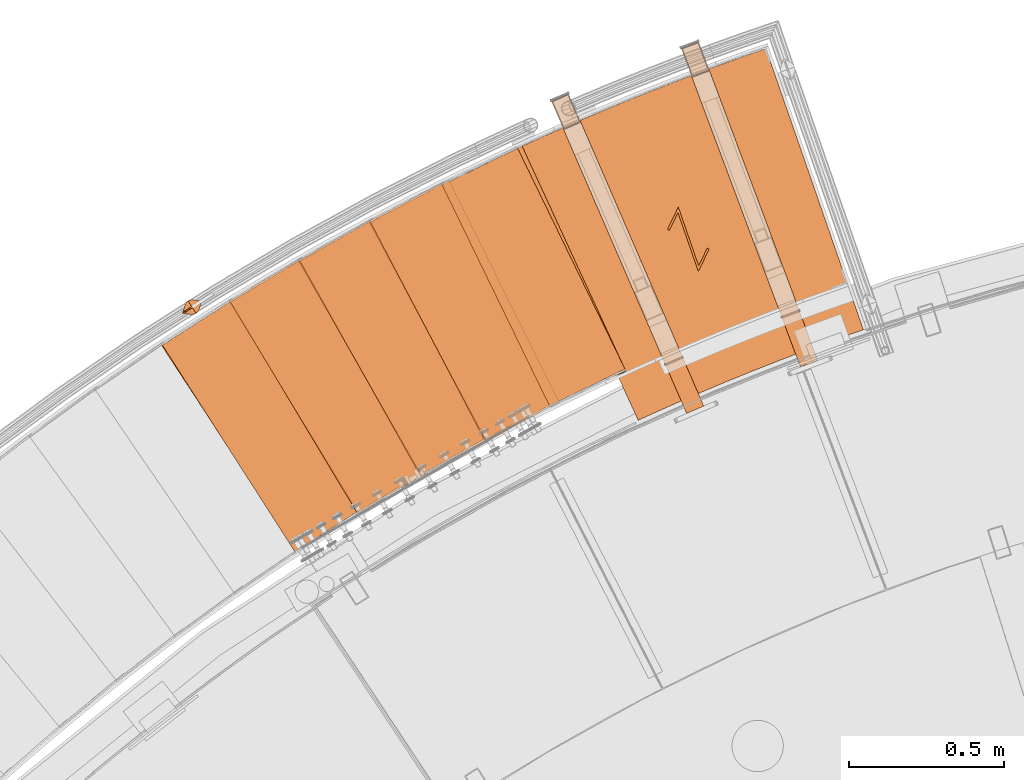
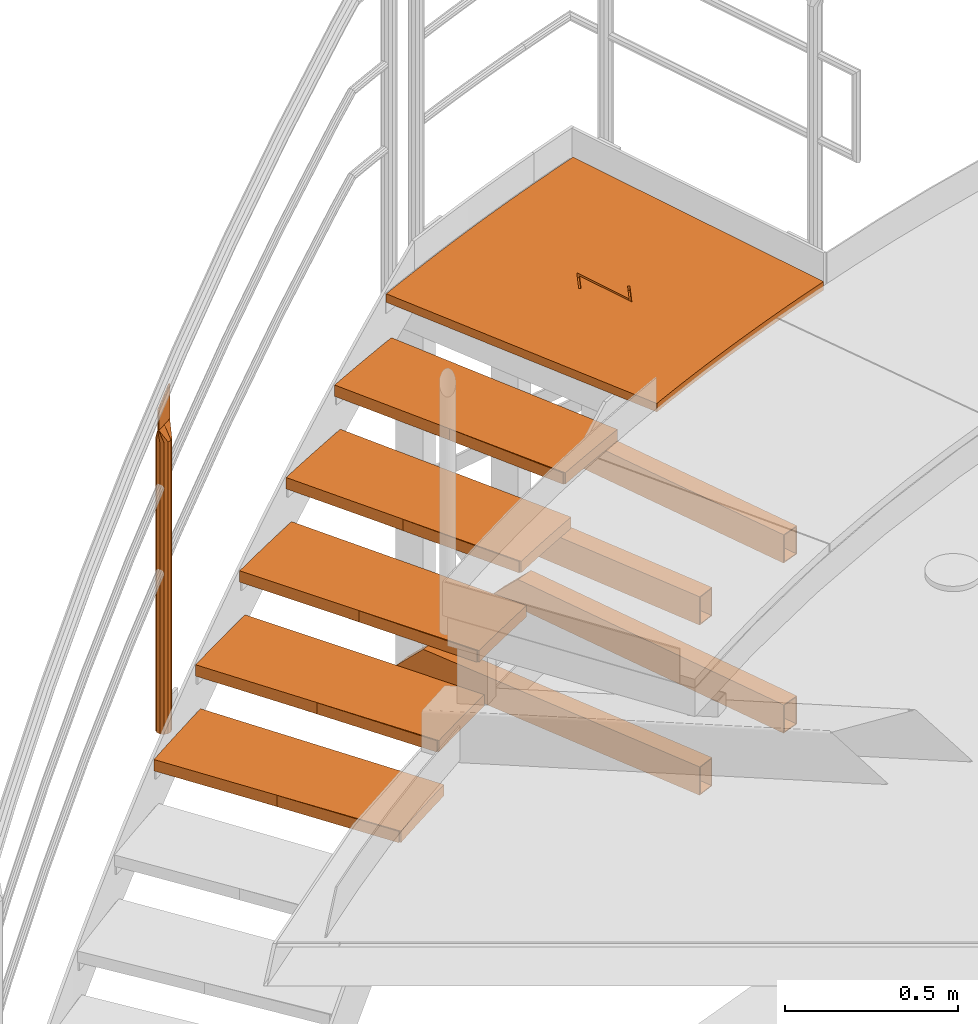
# One storey, part 37 of 126: 16 proxies.
"""IFC2X3 building model written with IfcOpenShell, lengths in millimetres."""

from ifc_helpers import new_model, si_unit, origin, origin_with_axes, place, context, project, spatial, faceted_brep, material, element, save


model = new_model("IFC2X3")

# Units and contexts
context_of_model_1 = context(None, 3, precision=0.1, world=origin())
context_of_model_2 = context(None, 3, precision=0.1, world=origin())
ifc_project = project(units=[si_unit("LENGTHUNIT", "METRE", prefix="MILLI"), si_unit("AREAUNIT", "SQUARE_METRE", prefix="CENTI"), si_unit("VOLUMEUNIT", "CUBIC_METRE", prefix="CENTI"), si_unit("MASSUNIT", "GRAM", prefix="KILO")], contexts=[context_of_model_1, context_of_model_2])

# Site, building, storey
site_placement = place(None, origin_with_axes())
site = spatial("IfcSite", under=ifc_project, at=site_placement, CompositionType="ELEMENT")
building_placement = place(site_placement, origin_with_axes())
building = spatial("IfcBuilding", under=site, at=building_placement, CompositionType="ELEMENT")
storey_placement = place(building_placement, origin_with_axes())
storey = spatial("IfcBuildingStorey", under=building, at=storey_placement, CompositionType="ELEMENT")

# Proxies
ifc_material_1 = material(Name="HOLZ")
proxy_1_placement = place(storey_placement, origin_with_axes())
element("IfcBuildingElementProxy", 1, at=proxy_1_placement, inside=storey, material=ifc_material_1, context=context_of_model_2, shape_type="Brep", body=[
    faceted_brep([(3425.4869, 15539.424, 10219.169), (3403.0134, 15525.719, 10219.169), (3380.5809, 15511.946, 10219.169), (3358.1896, 15498.106, 10219.169), (3335.8398, 15484.2, 10219.169), (3313.5316, 15470.227, 10219.169), (3291.2652, 15456.187, 10219.169), (3269.0408, 15442.081, 10219.169), (3246.8586, 15427.909, 10219.169), (3224.7188, 15413.671, 10219.169), (3202.6217, 15399.366, 10219.169), (3180.5673, 15384.996, 10219.169), (3618.3065, 14715.381, 10219.169), (3640.5956, 14729.899, 10219.169), (3662.9327, 14744.343, 10219.169), (3685.3176, 14758.712, 10219.169), (3707.7501, 14773.008, 10219.169), (3730.2299, 14787.229, 10219.169), (3752.7568, 14801.375, 10219.169), (3775.3305, 14815.447, 10219.169), (3797.9507, 14829.443, 10219.169), (3820.6173, 14843.365, 10219.169), (3843.3299, 14857.21, 10219.169), (3425.4869, 15539.424, 10179.169), (3843.3299, 14857.21, 10179.169), (3820.6173, 14843.365, 10179.169), (3797.9507, 14829.443, 10179.169), (3775.3305, 14815.447, 10179.169), (3752.7568, 14801.375, 10179.169), (3730.2299, 14787.229, 10179.169), (3707.7501, 14773.008, 10179.169), (3685.3176, 14758.712, 10179.169), (3662.9327, 14744.343, 10179.169), (3640.5956, 14729.899, 10179.169), (3618.3065, 14715.381, 10179.169), (3180.5673, 15384.996, 10179.169), (3202.6217, 15399.366, 10179.169), (3224.7188, 15413.671, 10179.169), (3246.8586, 15427.909, 10179.169), (3269.0408, 15442.081, 10179.169), (3291.2652, 15456.187, 10179.169), (3313.5316, 15470.227, 10179.169), (3335.8398, 15484.2, 10179.169), (3358.1896, 15498.106, 10179.169), (3380.5809, 15511.946, 10179.169), (3403.0134, 15525.719, 10179.169)], [[[0, 1, 2, 3, 4, 5, 6, 7, 8, 9, 10, 11, 12, 13, 14, 15, 16, 17, 18, 19, 20, 21, 22]], [[23, 24, 25, 26, 27, 28, 29, 30, 31, 32, 33, 34, 35, 36, 37, 38, 39, 40, 41, 42, 43, 44, 45]], [[0, 23, 45, 1]], [[1, 45, 44, 2]], [[2, 44, 43, 3]], [[3, 43, 42, 4]], [[4, 42, 41, 5]], [[5, 41, 40, 6]], [[6, 40, 39, 7]], [[7, 39, 38, 8]], [[8, 38, 37, 9]], [[9, 37, 36, 10]], [[10, 36, 35, 11]], [[11, 35, 34, 12]], [[12, 34, 33, 13]], [[13, 33, 32, 14]], [[14, 32, 31, 15]], [[15, 31, 30, 16]], [[16, 30, 29, 17]], [[17, 29, 28, 18]], [[18, 28, 27, 19]], [[19, 27, 26, 20]], [[20, 26, 25, 21]], [[21, 25, 24, 22]], [[22, 24, 23, 0]]]),
])
proxy_2_placement = place(storey_placement, origin_with_axes())
element("IfcBuildingElementProxy", 2, at=proxy_2_placement, inside=storey, material=ifc_material_1, context=context_of_model_2, shape_type="Brep", body=[
    faceted_brep([(3649.2363, 15670.951, 10392.375), (3626.3691, 15657.913, 10392.375), (3603.541, 15644.807, 10392.375), (3580.7521, 15631.632, 10392.375), (3558.0026, 15618.39, 10392.375), (3535.2928, 15605.079, 10392.375), (3512.6228, 15591.701, 10392.375), (3489.9928, 15578.255, 10392.375), (3467.4031, 15564.742, 10392.375), (3444.8538, 15551.162, 10392.375), (3422.3452, 15537.514, 10392.375), (3399.8774, 15523.799, 10392.375), (3817.7178, 14841.589, 10392.375), (3840.4245, 14855.445, 10392.375), (3863.1771, 14869.225, 10392.375), (3885.9753, 14882.93, 10392.375), (3908.8189, 14896.559, 10392.375), (3931.7075, 14910.112, 10392.375), (3954.641, 14923.589, 10392.375), (3977.619, 14936.99, 10392.375), (4000.6414, 14950.315, 10392.375), (4023.7079, 14963.563, 10392.375), (4046.8182, 14976.735, 10392.375), (3649.2363, 15670.951, 10352.375), (4046.8182, 14976.735, 10352.375), (4023.7079, 14963.563, 10352.375), (4000.6414, 14950.315, 10352.375), (3977.619, 14936.99, 10352.375), (3954.641, 14923.589, 10352.375), (3931.7075, 14910.112, 10352.375), (3908.8189, 14896.559, 10352.375), (3885.9753, 14882.93, 10352.375), (3863.1771, 14869.225, 10352.375), (3840.4245, 14855.445, 10352.375), (3817.7178, 14841.589, 10352.375), (3399.8774, 15523.799, 10352.375), (3422.3452, 15537.514, 10352.375), (3444.8538, 15551.162, 10352.375), (3467.4031, 15564.742, 10352.375), (3489.9928, 15578.255, 10352.375), (3512.6228, 15591.701, 10352.375), (3535.2928, 15605.079, 10352.375), (3558.0026, 15618.39, 10352.375), (3580.7521, 15631.632, 10352.375), (3603.541, 15644.807, 10352.375), (3626.3691, 15657.913, 10352.375)], [[[0, 1, 2, 3, 4, 5, 6, 7, 8, 9, 10, 11, 12, 13, 14, 15, 16, 17, 18, 19, 20, 21, 22]], [[23, 24, 25, 26, 27, 28, 29, 30, 31, 32, 33, 34, 35, 36, 37, 38, 39, 40, 41, 42, 43, 44, 45]], [[0, 23, 45, 1]], [[1, 45, 44, 2]], [[2, 44, 43, 3]], [[3, 43, 42, 4]], [[4, 42, 41, 5]], [[5, 41, 40, 6]], [[6, 40, 39, 7]], [[7, 39, 38, 8]], [[8, 38, 37, 9]], [[9, 37, 36, 10]], [[10, 36, 35, 11]], [[11, 35, 34, 12]], [[12, 34, 33, 13]], [[13, 33, 32, 14]], [[14, 32, 31, 15]], [[15, 31, 30, 16]], [[16, 30, 29, 17]], [[17, 29, 28, 18]], [[18, 28, 27, 19]], [[19, 27, 26, 20]], [[20, 26, 25, 21]], [[21, 25, 24, 22]], [[22, 24, 23, 0]]]),
])
proxy_3_placement = place(storey_placement, origin_with_axes())
element("IfcBuildingElementProxy", 3, at=proxy_3_placement, inside=storey, material=ifc_material_1, context=context_of_model_2, shape_type="Brep", body=[
    faceted_brep([(3876.76, 15795.836, 10565.581), (3853.519, 15783.476, 10565.581), (3830.315, 15771.048, 10565.581), (3807.1482, 15758.549, 10565.581), (3784.0188, 15745.982, 10565.581), (3760.927, 15733.346, 10565.581), (3737.8731, 15720.641, 10565.581), (3714.8572, 15707.867, 10565.581), (3691.8795, 15695.025, 10565.581), (3668.9403, 15682.114, 10565.581), (3646.0397, 15669.134, 10565.581), (3623.178, 15656.086, 10565.581), (4020.7575, 14961.874, 10565.581), (4043.8622, 14975.056, 10565.581), (4067.0105, 14988.16, 10565.581), (4090.2022, 15001.188, 10565.581), (4113.437, 15014.139, 10565.581), (4136.7146, 15027.012, 10565.581), (4160.0349, 15039.808, 10565.581), (4183.3974, 15052.527, 10565.581), (4206.802, 15065.169, 10565.581), (4230.2485, 15077.732, 10565.581), (4253.7365, 15090.218, 10565.581), (3876.76, 15795.836, 10525.581), (4253.7365, 15090.218, 10525.581), (4230.2485, 15077.732, 10525.581), (4206.802, 15065.169, 10525.581), (4183.3974, 15052.527, 10525.581), (4160.0349, 15039.808, 10525.581), (4136.7146, 15027.012, 10525.581), (4113.437, 15014.139, 10525.581), (4090.2022, 15001.188, 10525.581), (4067.0105, 14988.16, 10525.581), (4043.8622, 14975.056, 10525.581), (4020.7575, 14961.874, 10525.581), (3623.178, 15656.086, 10525.581), (3646.0397, 15669.134, 10525.581), (3668.9403, 15682.114, 10525.581), (3691.8795, 15695.025, 10525.581), (3714.8572, 15707.867, 10525.581), (3737.8731, 15720.641, 10525.581), (3760.927, 15733.346, 10525.581), (3784.0188, 15745.982, 10525.581), (3807.1482, 15758.549, 10525.581), (3830.315, 15771.048, 10525.581), (3853.519, 15783.476, 10525.581)], [[[0, 1, 2, 3, 4, 5, 6, 7, 8, 9, 10, 11, 12, 13, 14, 15, 16, 17, 18, 19, 20, 21, 22]], [[23, 24, 25, 26, 27, 28, 29, 30, 31, 32, 33, 34, 35, 36, 37, 38, 39, 40, 41, 42, 43, 44, 45]], [[0, 23, 45, 1]], [[1, 45, 44, 2]], [[2, 44, 43, 3]], [[3, 43, 42, 4]], [[4, 42, 41, 5]], [[5, 41, 40, 6]], [[6, 40, 39, 7]], [[7, 39, 38, 8]], [[8, 38, 37, 9]], [[9, 37, 36, 10]], [[10, 36, 35, 11]], [[11, 35, 34, 12]], [[12, 34, 33, 13]], [[13, 33, 32, 14]], [[14, 32, 31, 15]], [[15, 31, 30, 16]], [[16, 30, 29, 17]], [[17, 29, 28, 18]], [[18, 28, 27, 19]], [[19, 27, 26, 20]], [[20, 26, 25, 21]], [[21, 25, 24, 22]], [[22, 24, 23, 0]]]),
])
proxy_4_placement = place(storey_placement, origin_with_axes())
element("IfcBuildingElementProxy", 4, at=proxy_4_placement, inside=storey, material=ifc_material_1, context=context_of_model_2, shape_type="Brep", body=[
    faceted_brep([(4107.861, 15913.969, 10738.788), (4084.2663, 15902.299, 10738.788), (4060.7065, 15890.559, 10738.788), (4037.1819, 15878.748, 10738.788), (4013.6926, 15866.867, 10738.788), (3990.2389, 15854.916, 10738.788), (3966.821, 15842.895, 10738.788), (3943.4391, 15830.804, 10738.788), (3920.0934, 15818.644, 10738.788), (3896.7841, 15806.413, 10738.788), (3873.5114, 15794.113, 10738.788), (3850.2755, 15781.744, 10738.788), (4227.2496, 15076.131, 10738.788), (4250.7323, 15088.626, 10738.788), (4274.2563, 15101.044, 10738.788), (4297.8214, 15113.383, 10738.788), (4321.4273, 15125.645, 10738.788), (4345.0738, 15137.827, 10738.788), (4368.7605, 15149.932, 10738.788), (4392.4873, 15161.958, 10738.788), (4416.2539, 15173.904, 10738.788), (4440.0599, 15185.772, 10738.788), (4463.9052, 15197.561, 10738.788), (4107.861, 15913.969, 10698.788), (4463.9052, 15197.561, 10698.788), (4440.0599, 15185.772, 10698.788), (4416.2539, 15173.904, 10698.788), (4392.4873, 15161.958, 10698.788), (4368.7605, 15149.932, 10698.788), (4345.0738, 15137.827, 10698.788), (4321.4273, 15125.645, 10698.788), (4297.8214, 15113.383, 10698.788), (4274.2563, 15101.044, 10698.788), (4250.7323, 15088.626, 10698.788), (4227.2496, 15076.131, 10698.788), (3850.2755, 15781.744, 10698.788), (3873.5114, 15794.113, 10698.788), (3896.7841, 15806.413, 10698.788), (3920.0934, 15818.644, 10698.788), (3943.4391, 15830.804, 10698.788), (3966.821, 15842.895, 10698.788), (3990.2389, 15854.916, 10698.788), (4013.6926, 15866.867, 10698.788), (4037.1819, 15878.748, 10698.788), (4060.7065, 15890.559, 10698.788), (4084.2663, 15902.299, 10698.788)], [[[0, 1, 2, 3, 4, 5, 6, 7, 8, 9, 10, 11, 12, 13, 14, 15, 16, 17, 18, 19, 20, 21, 22]], [[23, 24, 25, 26, 27, 28, 29, 30, 31, 32, 33, 34, 35, 36, 37, 38, 39, 40, 41, 42, 43, 44, 45]], [[0, 23, 45, 1]], [[1, 45, 44, 2]], [[2, 44, 43, 3]], [[3, 43, 42, 4]], [[4, 42, 41, 5]], [[5, 41, 40, 6]], [[6, 40, 39, 7]], [[7, 39, 38, 8]], [[8, 38, 37, 9]], [[9, 37, 36, 10]], [[10, 36, 35, 11]], [[11, 35, 34, 12]], [[12, 34, 33, 13]], [[13, 33, 32, 14]], [[14, 32, 31, 15]], [[15, 31, 30, 16]], [[16, 30, 29, 17]], [[17, 29, 28, 18]], [[18, 28, 27, 19]], [[19, 27, 26, 20]], [[20, 26, 25, 21]], [[21, 25, 24, 22]], [[22, 24, 23, 0]]]),
])
proxy_5_placement = place(storey_placement, origin_with_axes())
element("IfcBuildingElementProxy", 5, at=proxy_5_placement, inside=storey, material=ifc_material_1, context=context_of_model_2, shape_type="Brep", body=[
    faceted_brep([(4342.339, 16025.25, 10911.994), (4318.411, 16014.279, 10911.994), (4294.5158, 16003.237, 10911.994), (4270.6537, 15992.124, 10911.994), (4246.825, 15980.939, 10911.994), (4223.0297, 15969.684, 10911.994), (4199.2681, 15958.357, 10911.994), (4175.5404, 15946.96, 10911.994), (4151.8469, 15935.492, 10911.994), (4128.1877, 15923.953, 10911.994), (4104.5631, 15912.343, 10911.994), (4080.9732, 15900.664, 10911.994), (4437.0152, 15184.26, 10911.994), (4460.8555, 15196.059, 10911.994), (4484.7348, 15207.779, 10911.994), (4508.6529, 15219.419, 10911.994), (4532.6095, 15230.98, 10911.994), (4556.6043, 15242.462, 10911.994), (4580.6371, 15253.864, 10911.994), (4604.7075, 15265.186, 10911.994), (4628.8154, 15276.428, 10911.994), (4652.9605, 15287.59, 10911.994), (4677.1425, 15298.672, 10911.994), (4342.339, 16025.25, 10871.994), (4677.1425, 15298.672, 10871.994), (4652.9605, 15287.59, 10871.994), (4628.8154, 15276.428, 10871.994), (4604.7075, 15265.186, 10871.994), (4580.6371, 15253.864, 10871.994), (4556.6043, 15242.462, 10871.994), (4532.6095, 15230.98, 10871.994), (4508.6529, 15219.419, 10871.994), (4484.7348, 15207.779, 10871.994), (4460.8555, 15196.059, 10871.994), (4437.0152, 15184.26, 10871.994), (4080.9732, 15900.664, 10871.994), (4104.5631, 15912.343, 10871.994), (4128.1877, 15923.953, 10871.994), (4151.8469, 15935.492, 10871.994), (4175.5404, 15946.96, 10871.994), (4199.2681, 15958.357, 10871.994), (4223.0297, 15969.684, 10871.994), (4246.825, 15980.939, 10871.994), (4270.6537, 15992.124, 10871.994), (4294.5158, 16003.237, 10871.994), (4318.411, 16014.279, 10871.994)], [[[0, 1, 2, 3, 4, 5, 6, 7, 8, 9, 10, 11, 12, 13, 14, 15, 16, 17, 18, 19, 20, 21, 22]], [[23, 24, 25, 26, 27, 28, 29, 30, 31, 32, 33, 34, 35, 36, 37, 38, 39, 40, 41, 42, 43, 44, 45]], [[0, 23, 45, 1]], [[1, 45, 44, 2]], [[2, 44, 43, 3]], [[3, 43, 42, 4]], [[4, 42, 41, 5]], [[5, 41, 40, 6]], [[6, 40, 39, 7]], [[7, 39, 38, 8]], [[8, 38, 37, 9]], [[9, 37, 36, 10]], [[10, 36, 35, 11]], [[11, 35, 34, 12]], [[12, 34, 33, 13]], [[13, 33, 32, 14]], [[14, 32, 31, 15]], [[15, 31, 30, 16]], [[16, 30, 29, 17]], [[17, 29, 28, 18]], [[18, 28, 27, 19]], [[19, 27, 26, 20]], [[20, 26, 25, 21]], [[21, 25, 24, 22]], [[22, 24, 23, 0]]]),
])
ifc_material_2 = material(Name="S235JRG2")
proxy_6_placement = place(storey_placement, origin_with_axes())
element("IfcBuildingElementProxy", 6, at=proxy_6_placement, inside=storey, material=ifc_material_2, context=context_of_model_2, shape_type="Brep", body=[
    faceted_brep([(3186.1898, 15382.68, 10178.71), (3186.1898, 15382.68, 10218.71), (3413.4653, 15528.439, 10218.71), (3413.4653, 15528.439, 10178.71), (3612.6711, 14717.688, 10178.71), (3839.9466, 14863.448, 10178.71), (3839.9466, 14863.448, 10218.71), (3612.6711, 14717.688, 10218.71)], [[[0, 1, 2, 3]], [[4, 5, 6, 7]], [[0, 4, 7, 1]], [[1, 7, 6, 2]], [[2, 6, 5, 3]], [[3, 5, 4, 0]]]),
])
proxy_7_placement = place(storey_placement, origin_with_axes())
element("IfcBuildingElementProxy", 7, at=proxy_7_placement, inside=storey, material=ifc_material_2, context=context_of_model_2, shape_type="Brep", body=[
    faceted_brep([(3405.4286, 15521.318, 10351.87), (3405.4286, 15521.318, 10391.87), (3636.8959, 15660.325, 10391.87), (3636.8959, 15660.325, 10351.87), (3812.1521, 14844.062, 10351.87), (4043.6194, 14983.068, 10351.87), (4043.6194, 14983.068, 10391.87), (3812.1521, 14844.062, 10391.87)], [[[0, 1, 2, 3]], [[4, 5, 6, 7]], [[0, 4, 7, 1]], [[1, 7, 6, 2]], [[2, 6, 5, 3]], [[3, 5, 4, 0]]]),
])
proxy_8_placement = place(storey_placement, origin_with_axes())
element("IfcBuildingElementProxy", 8, at=proxy_8_placement, inside=storey, material=ifc_material_2, context=context_of_model_2, shape_type="Brep", body=[
    faceted_brep([(3628.6531, 15653.443, 10525.03), (3628.6531, 15653.443, 10565.03), (3864.1116, 15785.577, 10565.03), (3864.1116, 15785.577, 10525.03), (4015.2664, 14964.509, 10525.03), (4250.7249, 15096.643, 10525.03), (4250.7249, 15096.643, 10565.03), (4015.2664, 14964.509, 10565.03)], [[[0, 1, 2, 3]], [[4, 5, 6, 7]], [[0, 4, 7, 1]], [[1, 7, 6, 2]], [[2, 6, 5, 3]], [[3, 5, 4, 0]]]),
])
proxy_9_placement = place(storey_placement, origin_with_axes())
element("IfcBuildingElementProxy", 9, at=proxy_9_placement, inside=storey, material=ifc_material_2, context=context_of_model_2, shape_type="Brep", body=[
    faceted_brep([(3855.6698, 15778.941, 10698.19), (3855.6698, 15778.941, 10738.19), (4094.9154, 15904.087, 10738.19), (4094.9154, 15904.087, 10698.19), (4221.8378, 15078.926, 10698.19), (4461.0834, 15204.072, 10698.19), (4461.0834, 15204.072, 10738.19), (4221.8378, 15078.926, 10738.19)], [[[0, 1, 2, 3]], [[4, 5, 6, 7]], [[0, 4, 7, 1]], [[1, 7, 6, 2]], [[2, 6, 5, 3]], [[3, 5, 4, 0]]]),
])
proxy_10_placement = place(storey_placement, origin_with_axes())
element("IfcBuildingElementProxy", 10, at=proxy_10_placement, inside=storey, material=ifc_material_2, context=context_of_model_2, shape_type="Brep", body=[
    faceted_brep([(4086.282, 15897.702, 10871.35), (4086.282, 15897.702, 10911.35), (4329.1074, 16015.752, 10911.35), (4329.1074, 16015.752, 10871.35), (4431.6874, 15187.213, 10871.35), (4674.5129, 15305.263, 10871.35), (4674.5129, 15305.263, 10911.35), (4431.6874, 15187.213, 10911.35)], [[[0, 1, 2, 3]], [[4, 5, 6, 7]], [[0, 4, 7, 1]], [[1, 7, 6, 2]], [[2, 6, 5, 3]], [[3, 5, 4, 0]]]),
])
proxy_11_placement = place(storey_placement, origin_with_axes())
element("IfcBuildingElementProxy", 11, at=proxy_11_placement, inside=storey, material=ifc_material_2, Name="BLECH", context=context_of_model_2, shape_type="Brep", body=[
    faceted_brep([(4716.9306, 15140.641, 11055.0), (4316.327, 16010.016, 11055.0), (4324.1825, 16013.636, 11055.0), (4339.9081, 16020.845, 11055.0), (4355.6479, 16028.023, 11055.0), (4371.4015, 16035.17, 11055.0), (4387.1693, 16042.286, 11055.0), (4402.9509, 16049.371, 11055.0), (4418.7462, 16056.425, 11055.0), (4434.5558, 16063.449, 11055.0), (4450.3787, 16070.441, 11055.0), (4466.2154, 16077.402, 11055.0), (4482.0658, 16084.332, 11055.0), (4497.9296, 16091.231, 11055.0), (4513.8072, 16098.098, 11055.0), (4529.6981, 16104.935, 11055.0), (4545.6023, 16111.74, 11055.0), (4561.5199, 16118.514, 11055.0), (4577.4508, 16125.257, 11055.0), (4593.3951, 16131.968, 11055.0), (4609.3522, 16138.649, 11055.0), (4625.3227, 16145.298, 11055.0), (4641.3061, 16151.915, 11055.0), (4657.3024, 16158.501, 11055.0), (4673.3115, 16165.056, 11055.0), (4689.3336, 16171.579, 11055.0), (4705.3681, 16178.071, 11055.0), (4721.416, 16184.532, 11055.0), (4737.4759, 16190.96, 11055.0), (4753.5487, 16197.358, 11055.0), (4769.6339, 16203.724, 11055.0), (4785.7316, 16210.058, 11055.0), (4801.8417, 16216.36, 11055.0), (4817.9643, 16222.631, 11055.0), (4834.0989, 16228.871, 11055.0), (4850.246, 16235.078, 11055.0), (4866.4051, 16241.254, 11055.0), (4882.5762, 16247.398, 11055.0), (4898.7597, 16253.511, 11055.0), (4914.9548, 16259.591, 11055.0), (4931.1619, 16265.64, 11055.0), (4947.381, 16271.657, 11055.0), (4963.6117, 16277.642, 11055.0), (4979.8539, 16283.596, 11055.0), (4996.1082, 16289.517, 11055.0), (5012.3735, 16295.407, 11055.0), (5028.6509, 16301.264, 11055.0), (5061.2399, 16312.884, 11055.0), (5077.551, 16318.645, 11055.0), (5093.8737, 16324.375, 11055.0), (5110.2075, 16330.072, 11055.0), (5118.3804, 16332.905, 11055.0), (5127.8287, 16336.181, 11055.0), (5441.3994, 15431.756, 11055.0), (5402.3487, 15418.161, 11055.0), (5355.8685, 15401.679, 11055.0), (5309.4927, 15384.905, 11055.0), (5263.2231, 15367.84, 11055.0), (5217.0616, 15350.485, 11055.0), (5171.0099, 15332.841, 11055.0), (5125.0698, 15314.908, 11055.0), (5079.2432, 15296.687, 11055.0), (5033.5319, 15278.179, 11055.0), (4987.9377, 15259.384, 11055.0), (4942.4623, 15240.303, 11055.0), (4897.1076, 15220.938, 11055.0), (4851.8753, 15201.288, 11055.0), (4806.7673, 15181.354, 11055.0), (4761.7853, 15161.138, 11055.0), (4716.9306, 15140.641, 11085.0), (4761.7853, 15161.138, 11085.0), (4806.7673, 15181.354, 11085.0), (4851.8753, 15201.288, 11085.0), (4897.1076, 15220.938, 11085.0), (4942.4623, 15240.303, 11085.0), (4987.9377, 15259.384, 11085.0), (5033.5319, 15278.179, 11085.0), (5079.2432, 15296.687, 11085.0), (5125.0698, 15314.908, 11085.0), (5171.0099, 15332.841, 11085.0), (5217.0616, 15350.485, 11085.0), (5263.2231, 15367.84, 11085.0), (5309.4927, 15384.905, 11085.0), (5355.8685, 15401.679, 11085.0), (5402.3487, 15418.161, 11085.0), (5441.3994, 15431.756, 11085.0), (5127.8287, 16336.181, 11085.0), (5118.3804, 16332.905, 11085.0), (5110.2075, 16330.072, 11085.0), (5093.8737, 16324.375, 11085.0), (5077.551, 16318.645, 11085.0), (5061.2399, 16312.884, 11085.0), (5028.6509, 16301.264, 11085.0), (5012.3735, 16295.407, 11085.0), (4996.1082, 16289.517, 11085.0), (4979.8539, 16283.596, 11085.0), (4963.6117, 16277.642, 11085.0), (4947.381, 16271.657, 11085.0), (4931.1619, 16265.64, 11085.0), (4914.9548, 16259.591, 11085.0), (4898.7597, 16253.511, 11085.0), (4882.5762, 16247.398, 11085.0), (4866.4051, 16241.254, 11085.0), (4850.246, 16235.078, 11085.0), (4834.0989, 16228.871, 11085.0), (4817.9643, 16222.631, 11085.0), (4801.8417, 16216.36, 11085.0), (4785.7316, 16210.058, 11085.0), (4769.6339, 16203.724, 11085.0), (4753.5487, 16197.358, 11085.0), (4737.4759, 16190.96, 11085.0), (4721.416, 16184.532, 11085.0), (4705.3681, 16178.071, 11085.0), (4689.3336, 16171.579, 11085.0), (4673.3115, 16165.056, 11085.0), (4657.3024, 16158.501, 11085.0), (4641.3061, 16151.915, 11085.0), (4625.3227, 16145.298, 11085.0), (4609.3522, 16138.649, 11085.0), (4593.3951, 16131.968, 11085.0), (4577.4508, 16125.257, 11085.0), (4561.5199, 16118.514, 11085.0), (4545.6023, 16111.74, 11085.0), (4529.6981, 16104.935, 11085.0), (4513.8072, 16098.098, 11085.0), (4497.9296, 16091.231, 11085.0), (4482.0658, 16084.332, 11085.0), (4466.2154, 16077.402, 11085.0), (4450.3787, 16070.441, 11085.0), (4434.5558, 16063.449, 11085.0), (4418.7462, 16056.425, 11085.0), (4402.9509, 16049.371, 11085.0), (4387.1693, 16042.286, 11085.0), (4371.4015, 16035.17, 11085.0), (4355.6479, 16028.023, 11085.0), (4339.9081, 16020.845, 11085.0), (4324.1825, 16013.636, 11085.0), (4316.327, 16010.016, 11085.0), (4817.2012, 15751.497, 11085.0), (4810.9032, 15754.552, 11085.0), (4845.8899, 15826.675, 11085.0), (4911.4054, 15637.71, 11085.0), (4939.0162, 15694.627, 11085.0), (4945.3143, 15691.572, 11085.0), (4910.3275, 15619.45, 11085.0), (4844.8121, 15808.415, 11085.0), (4817.2012, 15751.497, 11070.0), (4810.9032, 15754.552, 11070.0), (4845.8899, 15826.675, 11070.0), (4844.8121, 15808.415, 11070.0), (4911.4054, 15637.71, 11070.0), (4910.3275, 15619.45, 11070.0), (4939.0162, 15694.627, 11070.0), (4945.3143, 15691.572, 11070.0)], [[[0, 1, 2, 3, 4, 5, 6, 7, 8, 9, 10, 11, 12, 13, 14, 15, 16, 17, 18, 19, 20, 21, 22, 23, 24, 25, 26, 27, 28, 29, 30, 31, 32, 33, 34, 35, 36, 37, 38, 39, 40, 41, 42, 43, 44, 45, 46, 47, 48, 49, 50, 51, 52, 53, 54, 55, 56, 57, 58, 59, 60, 61, 62, 63, 64, 65, 66, 67, 68]], [[69, 70, 71, 72, 73, 74, 75, 76, 77, 78, 79, 80, 81, 82, 83, 84, 85, 86, 87, 88, 89, 90, 91, 92, 93, 94, 95, 96, 97, 98, 99, 100, 101, 102, 103, 104, 105, 106, 107, 108, 109, 110, 111, 112, 113, 114, 115, 116, 117, 118, 119, 120, 121, 122, 123, 124, 125, 126, 127, 128, 129, 130, 131, 132, 133, 134, 135, 136, 137], [138, 139, 140, 141, 142, 143, 144, 145]], [[2, 1, 137, 136]], [[2, 136, 135, 3]], [[3, 135, 134, 4]], [[4, 134, 133, 5]], [[5, 133, 132, 6]], [[6, 132, 131, 7]], [[7, 131, 130, 8]], [[8, 130, 129, 9]], [[9, 129, 128, 10]], [[10, 128, 127, 11]], [[11, 127, 126, 12]], [[12, 126, 125, 13]], [[13, 125, 124, 14]], [[14, 124, 123, 15]], [[15, 123, 122, 16]], [[16, 122, 121, 17]], [[17, 121, 120, 18]], [[18, 120, 119, 19]], [[19, 119, 118, 20]], [[20, 118, 117, 21]], [[21, 117, 116, 22]], [[22, 116, 115, 23]], [[23, 115, 114, 24]], [[24, 114, 113, 25]], [[25, 113, 112, 26]], [[26, 112, 111, 27]], [[27, 111, 110, 28]], [[28, 110, 109, 29]], [[29, 109, 108, 30]], [[30, 108, 107, 31]], [[31, 107, 106, 32]], [[32, 106, 105, 33]], [[33, 105, 104, 34]], [[34, 104, 103, 35]], [[35, 103, 102, 36]], [[36, 102, 101, 37]], [[37, 101, 100, 38]], [[38, 100, 99, 39]], [[39, 99, 98, 40]], [[40, 98, 97, 41]], [[41, 97, 96, 42]], [[42, 96, 95, 43]], [[43, 95, 94, 44]], [[44, 94, 93, 45]], [[45, 93, 92, 46]], [[46, 92, 91, 47]], [[47, 91, 90, 48]], [[48, 90, 89, 49]], [[49, 89, 88, 50]], [[50, 88, 87, 51]], [[51, 87, 86, 52]], [[52, 86, 85, 53]], [[53, 85, 84, 54]], [[54, 84, 83, 55]], [[55, 83, 82, 56]], [[56, 82, 81, 57]], [[57, 81, 80, 58]], [[58, 80, 79, 59]], [[59, 79, 78, 60]], [[60, 78, 77, 61]], [[61, 77, 76, 62]], [[62, 76, 75, 63]], [[63, 75, 74, 64]], [[64, 74, 73, 65]], [[65, 73, 72, 66]], [[66, 72, 71, 67]], [[67, 71, 70, 68]], [[0, 68, 70, 69]], [[0, 69, 137, 1]], [[138, 146, 147, 139]], [[139, 147, 148, 140]], [[147, 146, 149, 148]], [[138, 145, 149, 146]], [[140, 148, 150, 141]], [[148, 149, 151, 150]], [[144, 151, 149, 145]], [[141, 150, 152, 142]], [[150, 151, 153, 152]], [[143, 153, 151, 144]], [[142, 152, 153, 143]]]),
])
proxy_12_placement = place(storey_placement, origin_with_axes())
element("IfcBuildingElementProxy", 12, at=proxy_12_placement, inside=storey, material=ifc_material_2, context=context_of_model_2, shape_type="Brep", body=[
    faceted_brep([(5295.0114, 15333.017, 10235.15), (5238.8166, 15311.99, 10235.15), (4890.2306, 16243.581, 10235.15), (4946.4254, 16264.609, 10235.15), (4946.4255, 16264.608, 10335.15), (5295.0114, 15333.017, 10335.15), (4890.2307, 16243.581, 10335.15), (5238.8166, 15311.99, 10335.15), (5241.6263, 15313.041, 10332.15), (5241.6263, 15313.041, 10238.15), (4893.0404, 16244.633, 10238.15), (4893.0404, 16244.633, 10332.15), (4943.6158, 16263.557, 10332.15), (5292.2016, 15331.965, 10332.15), (4943.6157, 16263.557, 10238.15), (5292.2016, 15331.965, 10238.15)], [[[0, 1, 2, 3]], [[0, 3, 4, 5]], [[5, 4, 6, 7]], [[1, 7, 6, 2]], [[8, 9, 10, 11]], [[8, 11, 12, 13]], [[13, 12, 14, 15]], [[9, 15, 14, 10]], [[1, 0, 5, 7], [8, 13, 15, 9]], [[3, 2, 6, 4], [10, 14, 12, 11]]]),
])
proxy_13_placement = place(storey_placement, origin_with_axes())
element("IfcBuildingElementProxy", 13, at=proxy_13_placement, inside=storey, material=ifc_material_2, context=context_of_model_2, shape_type="Brep", body=[
    faceted_brep([(5295.0114, 15333.017, 9635.15), (5238.8166, 15311.99, 9635.15), (4855.1851, 16337.24, 9635.15), (4911.3799, 16358.267, 9635.15), (4946.4252, 16264.609, 9735.15), (5295.0114, 15333.017, 9735.15), (4890.2304, 16243.582, 9735.15), (5238.8166, 15311.99, 9735.15), (5241.6263, 15313.041, 9732.15), (5241.6263, 15313.041, 9638.15), (4859.0462, 16335.482, 9638.15), (4891.9888, 16247.443, 9732.15), (4942.5641, 16266.368, 9732.15), (5292.2016, 15331.965, 9732.15), (4909.6215, 16354.406, 9638.15), (5292.2016, 15331.965, 9638.15)], [[[0, 1, 2, 3]], [[0, 3, 4, 5]], [[4, 6, 7, 5]], [[1, 7, 6, 2]], [[8, 9, 10, 11]], [[8, 11, 12, 13]], [[12, 14, 15, 13]], [[9, 15, 14, 10]], [[1, 0, 5, 7], [8, 13, 15, 9]], [[3, 2, 6, 4], [10, 14, 12, 11]]]),
])
proxy_14_placement = place(storey_placement, origin_with_axes())
element("IfcBuildingElementProxy", 14, at=proxy_14_placement, inside=storey, material=ifc_material_2, context=context_of_model_2, shape_type="Brep", body=[
    faceted_brep([(4927.736, 15186.526, 10235.15), (4872.677, 15162.683, 10235.15), (4477.4055, 16075.445, 10235.15), (4532.4645, 16099.289, 10235.15), (4532.4646, 16099.289, 10335.15), (4927.736, 15186.526, 10335.15), (4477.4055, 16075.445, 10335.15), (4872.677, 15162.683, 10335.15), (4875.4299, 15163.875, 10332.15), (4875.4299, 15163.875, 10238.15), (4480.1584, 16076.638, 10238.15), (4480.1585, 16076.637, 10332.15), (4529.7116, 16098.096, 10332.15), (4924.9831, 15185.334, 10332.15), (4529.7116, 16098.097, 10238.15), (4924.9831, 15185.334, 10238.15)], [[[0, 1, 2, 3]], [[0, 3, 4, 5]], [[5, 4, 6, 7]], [[1, 7, 6, 2]], [[8, 9, 10, 11]], [[8, 11, 12, 13]], [[13, 12, 14, 15]], [[9, 15, 14, 10]], [[1, 0, 5, 7], [8, 13, 15, 9]], [[3, 2, 6, 4], [10, 14, 12, 11]]]),
])
proxy_15_placement = place(storey_placement, origin_with_axes())
element("IfcBuildingElementProxy", 15, at=proxy_15_placement, inside=storey, material=ifc_material_2, context=context_of_model_2, shape_type="Brep", body=[
    faceted_brep([(4927.736, 15186.526, 9635.15), (4872.677, 15162.683, 9635.15), (4437.6663, 16167.211, 9635.15), (4492.7254, 16191.055, 9635.15), (4532.4642, 16099.289, 9735.15), (4927.736, 15186.526, 9735.15), (4477.4052, 16075.446, 9735.15), (4872.677, 15162.683, 9735.15), (4875.4299, 15163.875, 9732.15), (4875.4299, 15163.875, 9638.15), (4441.6115, 16165.65, 9638.15), (4478.966, 16079.391, 9732.15), (4528.5191, 16100.85, 9732.15), (4924.9831, 15185.334, 9732.15), (4491.1646, 16187.109, 9638.15), (4924.9831, 15185.334, 9638.15)], [[[0, 1, 2, 3]], [[0, 3, 4, 5]], [[4, 6, 7, 5]], [[1, 7, 6, 2]], [[8, 9, 10, 11]], [[8, 11, 12, 13]], [[12, 14, 15, 13]], [[9, 15, 14, 10]], [[1, 0, 5, 7], [8, 13, 15, 9]], [[3, 2, 6, 4], [10, 14, 12, 11]]]),
])
ifc_material_3 = material(Name="1.4462")
proxy_16_placement = place(storey_placement, origin_with_axes())
element("IfcBuildingElementProxy", 16, at=proxy_16_placement, inside=storey, material=ifc_material_3, Name="Pfosten", context=context_of_model_2, shape_type="Brep", body=[
    faceted_brep([(3261.696, 15491.764, 11244.871), (3257.91, 15503.678, 11244.871), (3257.91, 15503.678, 10216.014), (3261.696, 15491.764, 10216.014), (3260.5883, 15515.889, 11244.871), (3260.5883, 15515.889, 10216.017), (3269.013, 15525.124, 11244.871), (3269.013, 15525.124, 10216.021), (3280.9269, 15528.91, 11244.871), (3280.9269, 15528.91, 10216.024), (3293.1376, 15526.232, 11244.871), (3293.1376, 15526.232, 10216.027), (3302.3733, 15517.807, 11244.871), (3302.3733, 15517.807, 10216.028), (3306.1592, 15505.893, 11244.871), (3306.1592, 15505.893, 10216.027), (3303.481, 15493.683, 11244.871), (3303.481, 15493.683, 10216.024), (3295.0562, 15484.447, 11244.871), (3295.0562, 15484.447, 10216.021), (3283.1423, 15480.661, 11244.871), (3283.1423, 15480.661, 10216.017), (3270.9316, 15483.339, 11244.871), (3270.9316, 15483.339, 10216.014), (3301.2609, 15494.832, 11244.871), (3303.6618, 15505.779, 11244.871), (3303.6618, 15505.779, 10216.026), (3301.2609, 15494.832, 10216.024), (3300.2678, 15516.459, 11244.871), (3300.2678, 15516.459, 10216.027), (3291.9883, 15524.012, 11244.871), (3291.9883, 15524.012, 10216.026), (3281.0416, 15526.413, 11244.871), (3281.0416, 15526.413, 10216.024), (3270.361, 15523.019, 11244.871), (3270.361, 15523.019, 10216.021), (3262.8084, 15514.739, 11244.871), (3262.8084, 15514.739, 10216.018), (3260.4074, 15503.793, 11244.871), (3260.4074, 15503.793, 10216.015), (3263.8014, 15493.112, 11244.871), (3263.8014, 15493.112, 10216.014), (3272.081, 15485.559, 11244.871), (3272.081, 15485.559, 10216.015), (3283.0276, 15483.158, 11244.871), (3283.0276, 15483.158, 10216.018), (3293.7082, 15486.552, 11244.871), (3293.7082, 15486.552, 10216.021), (3251.2885, 15485.101, 11293.171), (3250.952, 15486.984, 11293.171), (3252.046, 15488.554, 11293.171), (3280.6866, 15506.891, 11293.171), (3309.3273, 15525.228, 11293.171), (3311.2109, 15525.564, 11293.171), (3312.7807, 15524.47, 11293.171), (3313.1172, 15522.587, 11293.171), (3312.0233, 15521.017, 11293.171), (3283.3826, 15502.68, 11293.171), (3254.742, 15484.343, 11293.171), (3252.8584, 15484.007, 11293.171), (3310.7831, 15522.954, 11293.171), (3310.8706, 15523.08, 11293.171), (3310.8437, 15523.23, 11293.171), (3310.7181, 15523.318, 11293.171), (3310.5674, 15523.291, 11293.171), (3281.9268, 15504.954, 11293.171), (3253.2861, 15486.617, 11293.171), (3253.1986, 15486.492, 11293.171), (3253.2255, 15486.341, 11293.171), (3253.3511, 15486.253, 11293.171), (3253.5018, 15486.28, 11293.171), (3282.1425, 15504.617, 11293.171), (3251.2885, 15485.101, 11364.216), (3250.952, 15486.984, 11364.732), (3252.046, 15488.554, 11365.979), (3280.6866, 15506.891, 11389.957), (3309.3273, 15525.228, 11413.934), (3311.2109, 15525.564, 11415.181), (3312.7807, 15524.47, 11415.697), (3313.1172, 15522.587, 11415.181), (3312.0233, 15521.017, 11413.934), (3283.3826, 15502.68, 11389.957), (3254.742, 15484.343, 11365.979), (3252.8584, 15484.007, 11364.732), (3310.7831, 15522.954, 11413.934), (3310.8706, 15523.08, 11414.034), (3310.8437, 15523.23, 11414.076), (3310.7181, 15523.318, 11414.034), (3310.5674, 15523.291, 11413.934), (3281.9268, 15504.954, 11389.957), (3253.2861, 15486.617, 11365.979), (3253.1986, 15486.492, 11365.879), (3253.2255, 15486.341, 11365.838), (3253.3511, 15486.253, 11365.879), (3253.5018, 15486.28, 11365.979), (3282.1425, 15504.617, 11389.957)], [[[0, 1, 2, 3]], [[1, 4, 5, 2]], [[4, 6, 7, 5]], [[6, 8, 9, 7]], [[8, 10, 11, 9]], [[10, 12, 13, 11]], [[12, 14, 15, 13]], [[14, 16, 17, 15]], [[16, 18, 19, 17]], [[18, 20, 21, 19]], [[20, 22, 23, 21]], [[0, 3, 23, 22]], [[24, 25, 26, 27]], [[25, 28, 29, 26]], [[28, 30, 31, 29]], [[30, 32, 33, 31]], [[32, 34, 35, 33]], [[34, 36, 37, 35]], [[36, 38, 39, 37]], [[38, 40, 41, 39]], [[40, 42, 43, 41]], [[42, 44, 45, 43]], [[44, 46, 47, 45]], [[24, 27, 47, 46]], [[0, 48, 49, 1]], [[1, 49, 50, 4]], [[4, 50, 51, 6]], [[6, 51, 52, 8]], [[8, 52, 53, 10]], [[10, 53, 54, 12]], [[12, 54, 55, 14]], [[14, 55, 56, 16]], [[16, 56, 57, 18]], [[18, 57, 58, 20]], [[20, 58, 59, 22]], [[22, 59, 48, 0]], [[24, 60, 61, 25]], [[25, 61, 62, 28]], [[28, 62, 63, 30]], [[30, 63, 64, 32]], [[32, 64, 65, 34]], [[34, 65, 66, 36]], [[36, 66, 67, 38]], [[38, 67, 68, 40]], [[40, 68, 69, 42]], [[42, 69, 70, 44]], [[44, 70, 71, 46]], [[46, 71, 60, 24]], [[48, 72, 73, 49]], [[49, 73, 74, 50]], [[50, 74, 75, 51]], [[51, 75, 76, 52]], [[52, 76, 77, 53]], [[53, 77, 78, 54]], [[54, 78, 79, 55]], [[55, 79, 80, 56]], [[56, 80, 81, 57]], [[57, 81, 82, 58]], [[58, 82, 83, 59]], [[48, 59, 83, 72]], [[60, 84, 85, 61]], [[61, 85, 86, 62]], [[62, 86, 87, 63]], [[63, 87, 88, 64]], [[64, 88, 89, 65]], [[65, 89, 90, 66]], [[66, 90, 91, 67]], [[67, 91, 92, 68]], [[68, 92, 93, 69]], [[69, 93, 94, 70]], [[70, 94, 95, 71]], [[60, 71, 95, 84]], [[7, 9, 11, 13, 15, 17, 19, 21, 23, 3, 2, 5], [26, 29, 31, 33, 35, 37, 39, 41, 43, 45, 47, 27]], [[74, 73, 72, 83, 82, 81, 80, 79, 78, 77, 76, 75], [84, 95, 94, 93, 92, 91, 90, 89, 88, 87, 86, 85]]]),
])

save(model, "model.ifc")
